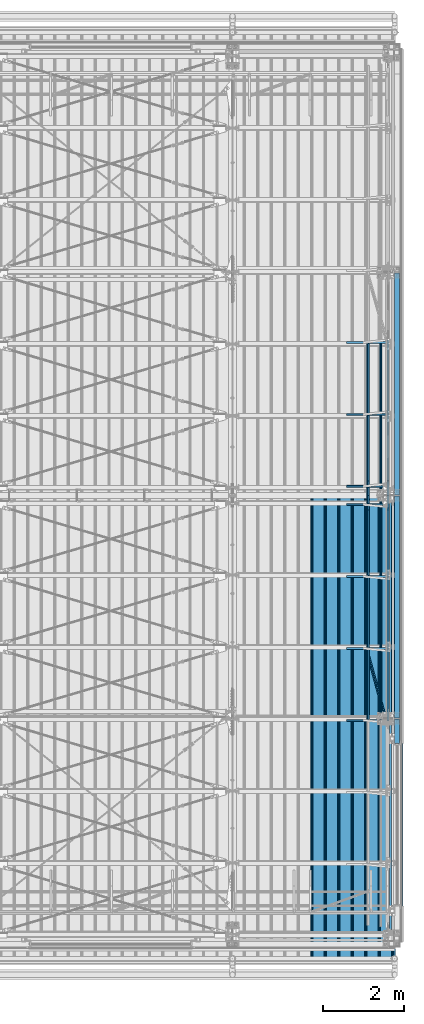
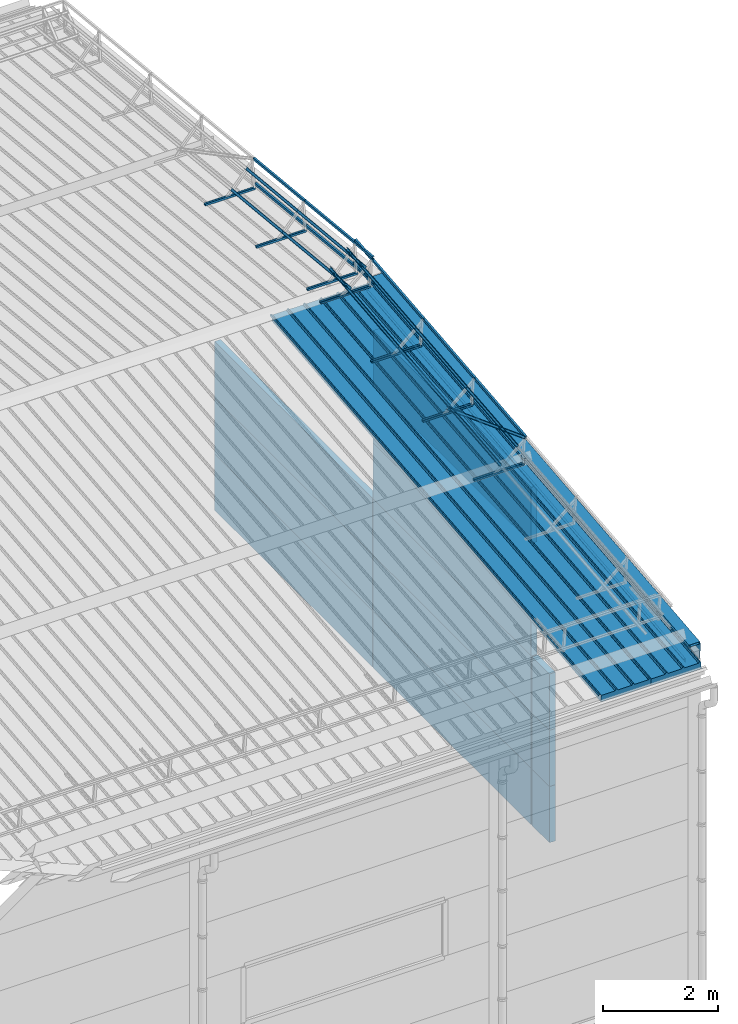
# One storey, part 73 of 709: 45 beams, 45 elements without a shape of their own.
"""IFC4 building model written with IfcOpenShell, lengths in millimetres."""

from ifc_helpers import new_model, si_unit, direction, frame, origin_with_axes, place, context, subcontext, project, spatial, line, indexed_curve, outline, extrude, material, element, aggregate, save


model = new_model("IFC4")

# Units and contexts
model_context = context("Model", 3, precision=0.2, world=origin_with_axes(), true_north=direction((0.0, 1.0)))
body_context = subcontext(model_context, "Body", "Model", "MODEL_VIEW")
ifc_project = project(units=[si_unit("LENGTHUNIT", "METRE", prefix="MILLI"), si_unit("AREAUNIT", "SQUARE_METRE"), si_unit("VOLUMEUNIT", "CUBIC_METRE"), si_unit("MASSUNIT", "GRAM", prefix="KILO"), si_unit("TIMEUNIT", "SECOND"), si_unit("PLANEANGLEUNIT", "RADIAN"), si_unit("SOLIDANGLEUNIT", "STERADIAN"), si_unit("THERMODYNAMICTEMPERATUREUNIT", "DEGREE_CELSIUS"), si_unit("LUMINOUSINTENSITYUNIT", "LUMEN")], contexts=[model_context])

# Site, building, storey
site_placement = place(None, origin_with_axes())
site = spatial("IfcSite", under=ifc_project, at=site_placement, CompositionType="ELEMENT")
building_placement = place(site_placement, origin_with_axes())
building = spatial("IfcBuilding", under=site, at=building_placement, Name="Undefined", CompositionType="ELEMENT")
storey_placement = place(building_placement, origin_with_axes())
storey = spatial("IfcBuildingStorey", under=building, at=storey_placement, Name="Undefined", CompositionType="ELEMENT", Elevation=0.0)

# Assembly, beam
assembly_1_placement = place(storey_placement, frame((49452.44, -410.89541, 7279.78979), z_axis=(1.0, 0.0, 0.0), x_axis=(0.0, 0.9950371902, 0.099503719)))
assembly_1 = element("IfcElementAssembly", 1, at=assembly_1_placement, inside=storey)
ifc_material_1 = material(Name="Insulation", Category="Insulation")
beam_1_placement = place(assembly_1_placement, origin_with_axes())
beam_1 = element("IfcBeam", 2, at=beam_1_placement, material=ifc_material_1, ObjectType="P-99", context=body_context, shape_type="SolidModel", body=[
    extrude(outline(indexed_curve([(-509.8453, 89.5), (-490.1547, 89.5), (-471.67949, 57.5), (-471.67949, -88.5), (-436.67949, -88.5), (-436.67949, -91.5), (562.55841, -91.5), (562.55841, -89.5), (527.55841, -89.5), (527.55841, 57.5), (510.2379, 88.5), (489.7621, 88.5), (472.44159, 58.5), (196.71923, 58.5), (177.66667, 91.5), (155.66667, 91.5), (136.61411, 58.5), (-136.61411, 58.5), (-155.66667, 91.5), (-177.66667, 91.5), (-196.71923, 58.5), (-469.94744, 58.5), (-489.0, 91.5), (-511.0, 91.5), (-527.16581, 63.5), (-525.43376, 62.5)], segments=[line(1, 2, 3, 4, 5, 6, 7, 8, 9, 10, 11, 12, 13, 14, 15, 16, 17, 18, 19, 20, 21, 22, 23, 24, 25, 26, 1)])), frame((0.0, 0.0, 0.0), z_axis=(-1.0, 0.0, 0.0), x_axis=(0.0, 0.0, 1.0)), (0.0, 0.0, -1.0), 11459.0),
])
aggregate(assembly_1, [beam_1])

assembly_2_placement = place(storey_placement, frame((48452.44, -410.89541, 7279.78979), z_axis=(1.0, 0.0, 0.0), x_axis=(0.0, 0.9950371902, 0.099503719)))
assembly_2 = element("IfcElementAssembly", 3, at=assembly_2_placement, inside=storey)
beam_2_placement = place(assembly_2_placement, origin_with_axes())
beam_2 = element("IfcBeam", 4, at=beam_2_placement, material=ifc_material_1, ObjectType="P-99", context=body_context, shape_type="SolidModel", body=[
    extrude(outline(indexed_curve([(-509.8453, 89.5), (-490.1547, 89.5), (-471.67949, 57.5), (-471.67949, -88.5), (-436.67949, -88.5), (-436.67949, -91.5), (562.55841, -91.5), (562.55841, -89.5), (527.55841, -89.5), (527.55841, 57.5), (510.2379, 88.5), (489.7621, 88.5), (472.44159, 58.5), (196.71923, 58.5), (177.66667, 91.5), (155.66667, 91.5), (136.61411, 58.5), (-136.61411, 58.5), (-155.66667, 91.5), (-177.66667, 91.5), (-196.71923, 58.5), (-469.94744, 58.5), (-489.0, 91.5), (-511.0, 91.5), (-527.16581, 63.5), (-525.43376, 62.5)], segments=[line(1, 2, 3, 4, 5, 6, 7, 8, 9, 10, 11, 12, 13, 14, 15, 16, 17, 18, 19, 20, 21, 22, 23, 24, 25, 26, 1)])), frame((0.0, 0.0, 0.0), z_axis=(-1.0, 0.0, 0.0), x_axis=(0.0, 0.0, 1.0)), (0.0, 0.0, -1.0), 11459.0),
])
aggregate(assembly_2, [beam_2])

assembly_3_placement = place(storey_placement, frame((49815.0, 5453.23325, 8045.59294), z_axis=(0.0, -0.099503719, 0.9950371902), x_axis=(-1.0, 0.0, 0.0)))
assembly_3 = element("IfcElementAssembly", 5, at=assembly_3_placement, inside=storey)
ifc_material_2 = material(Name="Steel_Undefined", Category="STEEL")
beam_3_placement = place(assembly_3_placement, origin_with_axes())
beam_3 = element("IfcBeam", 6, at=beam_3_placement, material=ifc_material_2, ObjectType="601", context=body_context, shape_type="SolidModel", body=[
    extrude(outline(indexed_curve([(-20.0, -25.0), (20.0, -25.0), (20.0, -22.5), (-17.5, -22.5), (-17.5, 22.5), (20.0, 22.5), (20.0, 25.0), (-20.0, 25.0)], segments=[line(1, 2, 3, 4, 5, 6, 7, 8, 1)])), frame((0.0, 0.0, 0.0), z_axis=(-1.0, 0.0, 0.0), x_axis=(0.0, 0.0, 1.0)), (0.0, 0.0, -1.0), 1000.0),
])
aggregate(assembly_3, [beam_3])

assembly_4_placement = place(storey_placement, frame((49815.0, 7226.5335, 8222.92296), z_axis=(0.0, -0.099503719, 0.9950371902), x_axis=(-1.0, 0.0, 0.0)))
assembly_4 = element("IfcElementAssembly", 7, at=assembly_4_placement, inside=storey)
beam_4_placement = place(assembly_4_placement, origin_with_axes())
beam_4 = element("IfcBeam", 8, at=beam_4_placement, material=ifc_material_2, ObjectType="601", context=body_context, shape_type="SolidModel", body=[
    extrude(outline(indexed_curve([(-20.0, -25.0), (20.0, -25.0), (20.0, -22.5), (-17.5, -22.5), (-17.5, 22.5), (20.0, 22.5), (20.0, 25.0), (-20.0, 25.0)], segments=[line(1, 2, 3, 4, 5, 6, 7, 8, 1)])), frame((0.0, 0.0, 0.0), z_axis=(-1.0, 0.0, 0.0), x_axis=(0.0, 0.0, 1.0)), (0.0, 0.0, -1.0), 1000.0),
])
aggregate(assembly_4, [beam_4])

assembly_5_placement = place(storey_placement, frame((49815.0, 8999.83375, 8400.25299), z_axis=(0.0, -0.099503719, 0.9950371902), x_axis=(-1.0, 0.0, 0.0)))
assembly_5 = element("IfcElementAssembly", 9, at=assembly_5_placement, inside=storey)
beam_5_placement = place(assembly_5_placement, origin_with_axes())
beam_5 = element("IfcBeam", 10, at=beam_5_placement, material=ifc_material_2, ObjectType="601", context=body_context, shape_type="SolidModel", body=[
    extrude(outline(indexed_curve([(-20.0, -25.0), (20.0, -25.0), (20.0, -22.5), (-17.5, -22.5), (-17.5, 22.5), (20.0, 22.5), (20.0, 25.0), (-20.0, 25.0)], segments=[line(1, 2, 3, 4, 5, 6, 7, 8, 1)])), frame((0.0, 0.0, 0.0), z_axis=(-1.0, 0.0, 0.0), x_axis=(0.0, 0.0, 1.0)), (0.0, 0.0, -1.0), 1000.0),
])
aggregate(assembly_5, [beam_5])

assembly_6_placement = place(storey_placement, frame((49815.0, 10773.134, 8577.58301), z_axis=(0.0, -0.099503719, 0.9950371902), x_axis=(-1.0, 0.0, 0.0)))
assembly_6 = element("IfcElementAssembly", 11, at=assembly_6_placement, inside=storey)
beam_6_placement = place(assembly_6_placement, origin_with_axes())
beam_6 = element("IfcBeam", 12, at=beam_6_placement, material=ifc_material_2, ObjectType="601", context=body_context, shape_type="SolidModel", body=[
    extrude(outline(indexed_curve([(-20.0, -25.0), (20.0, -25.0), (20.0, -22.5), (-17.5, -22.5), (-17.5, 22.5), (20.0, 22.5), (20.0, 25.0), (-20.0, 25.0)], segments=[line(1, 2, 3, 4, 5, 6, 7, 8, 1)])), frame((0.0, 0.0, 0.0), z_axis=(-1.0, 0.0, 0.0), x_axis=(0.0, 0.0, 1.0)), (0.0, 0.0, -1.0), 1000.0),
])
aggregate(assembly_6, [beam_6])

assembly_7_placement = place(storey_placement, frame((49835.0, 5395.5211, 8622.71451), z_axis=(1.0, 0.0, 0.0), x_axis=(0.0, 0.9950371902, 0.099503719)))
assembly_7 = element("IfcElementAssembly", 13, at=assembly_7_placement, inside=storey)
beam_7_placement = place(assembly_7_placement, origin_with_axes())
beam_7 = element("IfcBeam", 14, at=beam_7_placement, material=ifc_material_2, ObjectType="610", context=body_context, shape_type="SolidModel", body=[
    extrude(outline(indexed_curve([(-20.0, -25.0), (20.0, -25.0), (20.0, -22.5), (-17.5, -22.5), (-17.5, 22.5), (20.0, 22.5), (20.0, 25.0), (-20.0, 25.0)], segments=[line(1, 2, 3, 4, 5, 6, 7, 8, 1)])), frame((0.0, 0.0, 0.0), z_axis=(-1.0, 0.0, 0.0), x_axis=(0.0, 0.0, 1.0)), (0.0, 0.0, -1.0), 1782.14469),
])
aggregate(assembly_7, [beam_7])

assembly_8_placement = place(storey_placement, frame((49835.0, 5445.27295, 8125.19591), z_axis=(1.0, 0.0, 0.0), x_axis=(0.0, 0.9950371902, 0.099503719)))
assembly_8 = element("IfcElementAssembly", 15, at=assembly_8_placement, inside=storey)
beam_8_placement = place(assembly_8_placement, origin_with_axes())
beam_8 = element("IfcBeam", 16, at=beam_8_placement, material=ifc_material_2, ObjectType="610", context=body_context, shape_type="SolidModel", body=[
    extrude(outline(indexed_curve([(-20.0, -25.0), (20.0, -25.0), (20.0, -22.5), (-17.5, -22.5), (-17.5, 22.5), (20.0, 22.5), (20.0, 25.0), (-20.0, 25.0)], segments=[line(1, 2, 3, 4, 5, 6, 7, 8, 1)])), frame((0.0, 0.0, 0.0), z_axis=(-1.0, 0.0, 0.0), x_axis=(0.0, 0.0, 1.0)), (0.0, 0.0, -1.0), 1782.14469),
])
aggregate(assembly_8, [beam_8])

assembly_9_placement = place(storey_placement, frame((49659.43651, 5408.18585, 8496.06695), z_axis=(-0.707106781, -0.070359754, 0.703597545), x_axis=(0.0, 0.9950371902, 0.099503719)))
assembly_9 = element("IfcElementAssembly", 17, at=assembly_9_placement, inside=storey)
beam_9_placement = place(assembly_9_placement, origin_with_axes())
beam_9 = element("IfcBeam", 18, at=beam_9_placement, material=ifc_material_2, ObjectType="610", context=body_context, shape_type="SolidModel", body=[
    extrude(outline(indexed_curve([(-20.0, -25.0), (20.0, -25.0), (20.0, -22.5), (-17.5, -22.5), (-17.5, 22.5), (20.0, 22.5), (20.0, 25.0), (-20.0, 25.0)], segments=[line(1, 2, 3, 4, 5, 6, 7, 8, 1)])), frame((0.0, 0.0, 0.0), z_axis=(-1.0, 0.0, 0.0), x_axis=(0.0, 0.0, 1.0)), (0.0, 0.0, -1.0), 1782.14469),
])
aggregate(assembly_9, [beam_9])

assembly_10_placement = place(storey_placement, frame((49342.27922, 5439.74418, 8180.48365), z_axis=(-0.707106781, -0.070359754, 0.703597545), x_axis=(0.0, 0.9950371902, 0.099503719)))
assembly_10 = element("IfcElementAssembly", 19, at=assembly_10_placement, inside=storey)
beam_10_placement = place(assembly_10_placement, origin_with_axes())
beam_10 = element("IfcBeam", 20, at=beam_10_placement, material=ifc_material_2, ObjectType="610", context=body_context, shape_type="SolidModel", body=[
    extrude(outline(indexed_curve([(-20.0, -25.0), (20.0, -25.0), (20.0, -22.5), (-17.5, -22.5), (-17.5, 22.5), (20.0, 22.5), (20.0, 25.0), (-20.0, 25.0)], segments=[line(1, 2, 3, 4, 5, 6, 7, 8, 1)])), frame((0.0, 0.0, 0.0), z_axis=(-1.0, 0.0, 0.0), x_axis=(0.0, 0.0, 1.0)), (0.0, 0.0, -1.0), 1782.14469),
])
aggregate(assembly_10, [beam_10])

assembly_11_placement = place(storey_placement, frame((49835.0, 7168.82134, 8800.04453), z_axis=(1.0, 0.0, 0.0), x_axis=(0.0, 0.9950371902, 0.099503719)))
assembly_11 = element("IfcElementAssembly", 21, at=assembly_11_placement, inside=storey)
beam_11_placement = place(assembly_11_placement, origin_with_axes())
beam_11 = element("IfcBeam", 22, at=beam_11_placement, material=ifc_material_2, ObjectType="610", context=body_context, shape_type="SolidModel", body=[
    extrude(outline(indexed_curve([(-20.0, -25.0), (20.0, -25.0), (20.0, -22.5), (-17.5, -22.5), (-17.5, 22.5), (20.0, 22.5), (20.0, 25.0), (-20.0, 25.0)], segments=[line(1, 2, 3, 4, 5, 6, 7, 8, 1)])), frame((0.0, 0.0, 0.0), z_axis=(-1.0, 0.0, 0.0), x_axis=(0.0, 0.0, 1.0)), (0.0, 0.0, -1.0), 1782.14469),
])
aggregate(assembly_11, [beam_11])

assembly_12_placement = place(storey_placement, frame((49835.0, 7218.5732, 8302.52594), z_axis=(1.0, 0.0, 0.0), x_axis=(0.0, 0.9950371902, 0.099503719)))
assembly_12 = element("IfcElementAssembly", 23, at=assembly_12_placement, inside=storey)
beam_12_placement = place(assembly_12_placement, origin_with_axes())
beam_12 = element("IfcBeam", 24, at=beam_12_placement, material=ifc_material_2, ObjectType="610", context=body_context, shape_type="SolidModel", body=[
    extrude(outline(indexed_curve([(-20.0, -25.0), (20.0, -25.0), (20.0, -22.5), (-17.5, -22.5), (-17.5, 22.5), (20.0, 22.5), (20.0, 25.0), (-20.0, 25.0)], segments=[line(1, 2, 3, 4, 5, 6, 7, 8, 1)])), frame((0.0, 0.0, 0.0), z_axis=(-1.0, 0.0, 0.0), x_axis=(0.0, 0.0, 1.0)), (0.0, 0.0, -1.0), 1782.14469),
])
aggregate(assembly_12, [beam_12])

assembly_13_placement = place(storey_placement, frame((49659.43651, 7181.4861, 8673.39698), z_axis=(-0.707106781, -0.070359754, 0.703597545), x_axis=(0.0, 0.9950371902, 0.099503719)))
assembly_13 = element("IfcElementAssembly", 25, at=assembly_13_placement, inside=storey)
beam_13_placement = place(assembly_13_placement, origin_with_axes())
beam_13 = element("IfcBeam", 26, at=beam_13_placement, material=ifc_material_2, ObjectType="610", context=body_context, shape_type="SolidModel", body=[
    extrude(outline(indexed_curve([(-20.0, -25.0), (20.0, -25.0), (20.0, -22.5), (-17.5, -22.5), (-17.5, 22.5), (20.0, 22.5), (20.0, 25.0), (-20.0, 25.0)], segments=[line(1, 2, 3, 4, 5, 6, 7, 8, 1)])), frame((0.0, 0.0, 0.0), z_axis=(-1.0, 0.0, 0.0), x_axis=(0.0, 0.0, 1.0)), (0.0, 0.0, -1.0), 1782.14469),
])
aggregate(assembly_13, [beam_13])

assembly_14_placement = place(storey_placement, frame((49342.27922, 7213.04443, 8357.81368), z_axis=(-0.707106781, -0.070359754, 0.703597545), x_axis=(0.0, 0.9950371902, 0.099503719)))
assembly_14 = element("IfcElementAssembly", 27, at=assembly_14_placement, inside=storey)
beam_14_placement = place(assembly_14_placement, origin_with_axes())
beam_14 = element("IfcBeam", 28, at=beam_14_placement, material=ifc_material_2, ObjectType="610", context=body_context, shape_type="SolidModel", body=[
    extrude(outline(indexed_curve([(-20.0, -25.0), (20.0, -25.0), (20.0, -22.5), (-17.5, -22.5), (-17.5, 22.5), (20.0, 22.5), (20.0, 25.0), (-20.0, 25.0)], segments=[line(1, 2, 3, 4, 5, 6, 7, 8, 1)])), frame((0.0, 0.0, 0.0), z_axis=(-1.0, 0.0, 0.0), x_axis=(0.0, 0.0, 1.0)), (0.0, 0.0, -1.0), 1782.14469),
])
aggregate(assembly_14, [beam_14])

assembly_15_placement = place(storey_placement, frame((49835.0, 8942.12159, 8977.37456), z_axis=(1.0, 0.0, 0.0), x_axis=(0.0, 0.9950371902, 0.099503719)))
assembly_15 = element("IfcElementAssembly", 29, at=assembly_15_placement, inside=storey)
beam_15_placement = place(assembly_15_placement, origin_with_axes())
beam_15 = element("IfcBeam", 30, at=beam_15_placement, material=ifc_material_2, ObjectType="611", context=body_context, shape_type="SolidModel", body=[
    extrude(outline(indexed_curve([(-20.0, -25.0), (20.0, -25.0), (20.0, -22.5), (-17.5, -22.5), (-17.5, 22.5), (20.0, 22.5), (20.0, 25.0), (-20.0, 25.0)], segments=[line(1, 2, 3, 4, 5, 6, 7, 8, 1)])), frame((0.0, 0.0, 0.0), z_axis=(-1.0, 0.0, 0.0), x_axis=(0.0, 0.0, 1.0)), (0.0, 0.0, -1.0), 2382.14469),
])
aggregate(assembly_15, [beam_15])

assembly_16_placement = place(storey_placement, frame((49835.0, 8991.87345, 8479.85596), z_axis=(1.0, 0.0, 0.0), x_axis=(0.0, 0.9950371902, 0.099503719)))
assembly_16 = element("IfcElementAssembly", 31, at=assembly_16_placement, inside=storey)
beam_16_placement = place(assembly_16_placement, origin_with_axes())
beam_16 = element("IfcBeam", 32, at=beam_16_placement, material=ifc_material_2, ObjectType="611", context=body_context, shape_type="SolidModel", body=[
    extrude(outline(indexed_curve([(-20.0, -25.0), (20.0, -25.0), (20.0, -22.5), (-17.5, -22.5), (-17.5, 22.5), (20.0, 22.5), (20.0, 25.0), (-20.0, 25.0)], segments=[line(1, 2, 3, 4, 5, 6, 7, 8, 1)])), frame((0.0, 0.0, 0.0), z_axis=(-1.0, 0.0, 0.0), x_axis=(0.0, 0.0, 1.0)), (0.0, 0.0, -1.0), 2382.14469),
])
aggregate(assembly_16, [beam_16])

assembly_17_placement = place(storey_placement, frame((49659.43651, 8954.78635, 8850.727), z_axis=(-0.707106781, -0.070359754, 0.703597545), x_axis=(0.0, 0.9950371902, 0.099503719)))
assembly_17 = element("IfcElementAssembly", 33, at=assembly_17_placement, inside=storey)
beam_17_placement = place(assembly_17_placement, origin_with_axes())
beam_17 = element("IfcBeam", 34, at=beam_17_placement, material=ifc_material_2, ObjectType="611", context=body_context, shape_type="SolidModel", body=[
    extrude(outline(indexed_curve([(-20.0, -25.0), (20.0, -25.0), (20.0, -22.5), (-17.5, -22.5), (-17.5, 22.5), (20.0, 22.5), (20.0, 25.0), (-20.0, 25.0)], segments=[line(1, 2, 3, 4, 5, 6, 7, 8, 1)])), frame((0.0, 0.0, 0.0), z_axis=(-1.0, 0.0, 0.0), x_axis=(0.0, 0.0, 1.0)), (0.0, 0.0, -1.0), 2382.14469),
])
aggregate(assembly_17, [beam_17])

assembly_18_placement = place(storey_placement, frame((49342.27922, 8986.34468, 8535.1437), z_axis=(-0.707106781, -0.070359754, 0.703597545), x_axis=(0.0, 0.9950371902, 0.099503719)))
assembly_18 = element("IfcElementAssembly", 35, at=assembly_18_placement, inside=storey)
beam_18_placement = place(assembly_18_placement, origin_with_axes())
beam_18 = element("IfcBeam", 36, at=beam_18_placement, material=ifc_material_2, ObjectType="611", context=body_context, shape_type="SolidModel", body=[
    extrude(outline(indexed_curve([(-20.0, -25.0), (20.0, -25.0), (20.0, -22.5), (-17.5, -22.5), (-17.5, 22.5), (20.0, 22.5), (20.0, 25.0), (-20.0, 25.0)], segments=[line(1, 2, 3, 4, 5, 6, 7, 8, 1)])), frame((0.0, 0.0, 0.0), z_axis=(-1.0, 0.0, 0.0), x_axis=(0.0, 0.0, 1.0)), (0.0, 0.0, -1.0), 2382.14469),
])
aggregate(assembly_18, [beam_18])

assembly_19_placement = place(storey_placement, frame((49800.85786, 5394.1139, 8636.78646), z_axis=(-0.707106781, -0.070359754, 0.703597545), x_axis=(-0.2585142339, 0.9518781635, -0.1646157729)))
assembly_19 = element("IfcElementAssembly", 37, at=assembly_19_placement, inside=storey)
beam_19_placement = place(assembly_19_placement, origin_with_axes())
beam_19 = element("IfcBeam", 38, at=beam_19_placement, material=ifc_material_2, ObjectType="612", context=body_context, shape_type="SolidModel", body=[
    extrude(outline(indexed_curve([(-20.0, -25.0), (20.0, -25.0), (20.0, -22.5), (-17.5, -22.5), (-17.5, 22.5), (20.0, 22.5), (20.0, 25.0), (-20.0, 25.0)], segments=[line(1, 2, 3, 4, 5, 6, 7, 8, 1)])), frame((0.0, 0.0, 0.0), z_axis=(-1.0, 0.0, 0.0), x_axis=(0.0, 0.0, 1.0)), (0.0, 0.0, -1.0), 1914.6905),
])
aggregate(assembly_19, [beam_19])

assembly_20_placement = place(storey_placement, frame((49815.0, 11226.866, 8577.58301), z_axis=(0.0, 0.099503719, 0.9950371902), x_axis=(-1.0, 0.0, 0.0)))
assembly_20 = element("IfcElementAssembly", 39, at=assembly_20_placement, inside=storey)
beam_20_placement = place(assembly_20_placement, origin_with_axes())
beam_20 = element("IfcBeam", 40, at=beam_20_placement, material=ifc_material_2, ObjectType="601", context=body_context, shape_type="SolidModel", body=[
    extrude(outline(indexed_curve([(-20.0, -25.0), (20.0, -25.0), (20.0, -22.5), (-17.5, -22.5), (-17.5, 22.5), (20.0, 22.5), (20.0, 25.0), (-20.0, 25.0)], segments=[line(1, 2, 3, 4, 5, 6, 7, 8, 1)])), frame((0.0, 0.0, 0.0), z_axis=(-1.0, 0.0, 0.0), x_axis=(0.0, 0.0, 1.0)), (0.0, 0.0, -1.0), 1000.0),
])
aggregate(assembly_20, [beam_20])

assembly_21_placement = place(storey_placement, frame((49815.0, 13000.16625, 8400.25299), z_axis=(0.0, 0.099503719, 0.9950371902), x_axis=(-1.0, 0.0, 0.0)))
assembly_21 = element("IfcElementAssembly", 41, at=assembly_21_placement, inside=storey)
beam_21_placement = place(assembly_21_placement, origin_with_axes())
beam_21 = element("IfcBeam", 42, at=beam_21_placement, material=ifc_material_2, ObjectType="601", context=body_context, shape_type="SolidModel", body=[
    extrude(outline(indexed_curve([(-20.0, -25.0), (20.0, -25.0), (20.0, -22.5), (-17.5, -22.5), (-17.5, 22.5), (20.0, 22.5), (20.0, 25.0), (-20.0, 25.0)], segments=[line(1, 2, 3, 4, 5, 6, 7, 8, 1)])), frame((0.0, 0.0, 0.0), z_axis=(-1.0, 0.0, 0.0), x_axis=(0.0, 0.0, 1.0)), (0.0, 0.0, -1.0), 1000.0),
])
aggregate(assembly_21, [beam_21])

assembly_22_placement = place(storey_placement, frame((49815.0, 14773.4665, 8222.92296), z_axis=(0.0, 0.099503719, 0.9950371902), x_axis=(-1.0, 0.0, 0.0)))
assembly_22 = element("IfcElementAssembly", 43, at=assembly_22_placement, inside=storey)
beam_22_placement = place(assembly_22_placement, origin_with_axes())
beam_22 = element("IfcBeam", 44, at=beam_22_placement, material=ifc_material_2, ObjectType="601", context=body_context, shape_type="SolidModel", body=[
    extrude(outline(indexed_curve([(-20.0, -25.0), (20.0, -25.0), (20.0, -22.5), (-17.5, -22.5), (-17.5, 22.5), (20.0, 22.5), (20.0, 25.0), (-20.0, 25.0)], segments=[line(1, 2, 3, 4, 5, 6, 7, 8, 1)])), frame((0.0, 0.0, 0.0), z_axis=(-1.0, 0.0, 0.0), x_axis=(0.0, 0.0, 1.0)), (0.0, 0.0, -1.0), 1000.0),
])
aggregate(assembly_22, [beam_22])

assembly_23_placement = place(storey_placement, frame((49835.0, 10687.55585, 9214.40681), z_axis=(1.0, 0.0, 0.0), x_axis=(0.0, 0.9950371902, -0.099503719)))
assembly_23 = element("IfcElementAssembly", 45, at=assembly_23_placement, inside=storey)
beam_23_placement = place(assembly_23_placement, origin_with_axes())
beam_23 = element("IfcBeam", 46, at=beam_23_placement, material=ifc_material_2, ObjectType="611", context=body_context, shape_type="SolidModel", body=[
    extrude(outline(indexed_curve([(-20.0, -25.0), (20.0, -25.0), (20.0, -22.5), (-17.5, -22.5), (-17.5, 22.5), (20.0, 22.5), (20.0, 25.0), (-20.0, 25.0)], segments=[line(1, 2, 3, 4, 5, 6, 7, 8, 1)])), frame((0.0, 0.0, 0.0), z_axis=(-1.0, 0.0, 0.0), x_axis=(0.0, 0.0, 1.0)), (0.0, 0.0, -1.0), 2382.14469),
])
aggregate(assembly_23, [beam_23])

assembly_24_placement = place(storey_placement, frame((49835.0, 10637.80399, 8716.88822), z_axis=(1.0, 0.0, 0.0), x_axis=(0.0, 0.9950371902, -0.099503719)))
assembly_24 = element("IfcElementAssembly", 47, at=assembly_24_placement, inside=storey)
beam_24_placement = place(assembly_24_placement, origin_with_axes())
beam_24 = element("IfcBeam", 48, at=beam_24_placement, material=ifc_material_2, ObjectType="611", context=body_context, shape_type="SolidModel", body=[
    extrude(outline(indexed_curve([(-20.0, -25.0), (20.0, -25.0), (20.0, -22.5), (-17.5, -22.5), (-17.5, 22.5), (20.0, 22.5), (20.0, 25.0), (-20.0, 25.0)], segments=[line(1, 2, 3, 4, 5, 6, 7, 8, 1)])), frame((0.0, 0.0, 0.0), z_axis=(-1.0, 0.0, 0.0), x_axis=(0.0, 0.0, 1.0)), (0.0, 0.0, -1.0), 2382.14469),
])
aggregate(assembly_24, [beam_24])

assembly_25_placement = place(storey_placement, frame((49659.43651, 10674.89109, 9087.75926), z_axis=(-0.7071067814, 0.0703597545, 0.7035975445), x_axis=(0.0, 0.9950371902, -0.099503719)))
assembly_25 = element("IfcElementAssembly", 49, at=assembly_25_placement, inside=storey)
beam_25_placement = place(assembly_25_placement, origin_with_axes())
beam_25 = element("IfcBeam", 50, at=beam_25_placement, material=ifc_material_2, ObjectType="611", context=body_context, shape_type="SolidModel", body=[
    extrude(outline(indexed_curve([(-20.0, -25.0), (20.0, -25.0), (20.0, -22.5), (-17.5, -22.5), (-17.5, 22.5), (20.0, 22.5), (20.0, 25.0), (-20.0, 25.0)], segments=[line(1, 2, 3, 4, 5, 6, 7, 8, 1)])), frame((0.0, 0.0, 0.0), z_axis=(-1.0, 0.0, 0.0), x_axis=(0.0, 0.0, 1.0)), (0.0, 0.0, -1.0), 2382.14469),
])
aggregate(assembly_25, [beam_25])

assembly_26_placement = place(storey_placement, frame((49342.27922, 10643.33276, 8772.17596), z_axis=(-0.7071067814, 0.0703597545, 0.7035975445), x_axis=(0.0, 0.9950371902, -0.099503719)))
assembly_26 = element("IfcElementAssembly", 51, at=assembly_26_placement, inside=storey)
beam_26_placement = place(assembly_26_placement, origin_with_axes())
beam_26 = element("IfcBeam", 52, at=beam_26_placement, material=ifc_material_2, ObjectType="611", context=body_context, shape_type="SolidModel", body=[
    extrude(outline(indexed_curve([(-20.0, -25.0), (20.0, -25.0), (20.0, -22.5), (-17.5, -22.5), (-17.5, 22.5), (20.0, 22.5), (20.0, 25.0), (-20.0, 25.0)], segments=[line(1, 2, 3, 4, 5, 6, 7, 8, 1)])), frame((0.0, 0.0, 0.0), z_axis=(-1.0, 0.0, 0.0), x_axis=(0.0, 0.0, 1.0)), (0.0, 0.0, -1.0), 2382.14469),
])
aggregate(assembly_26, [beam_26])

assembly_27_placement = place(storey_placement, frame((49835.0, 13057.87841, 8977.37456), z_axis=(1.0, 0.0, 0.0), x_axis=(0.0, 0.9950371902, -0.099503719)))
assembly_27 = element("IfcElementAssembly", 53, at=assembly_27_placement, inside=storey)
beam_27_placement = place(assembly_27_placement, origin_with_axes())
beam_27 = element("IfcBeam", 54, at=beam_27_placement, material=ifc_material_2, ObjectType="610", context=body_context, shape_type="SolidModel", body=[
    extrude(outline(indexed_curve([(-20.0, -25.0), (20.0, -25.0), (20.0, -22.5), (-17.5, -22.5), (-17.5, 22.5), (20.0, 22.5), (20.0, 25.0), (-20.0, 25.0)], segments=[line(1, 2, 3, 4, 5, 6, 7, 8, 1)])), frame((0.0, 0.0, 0.0), z_axis=(-1.0, 0.0, 0.0), x_axis=(0.0, 0.0, 1.0)), (0.0, 0.0, -1.0), 1782.14469),
])
aggregate(assembly_27, [beam_27])

assembly_28_placement = place(storey_placement, frame((49835.0, 13008.12655, 8479.85596), z_axis=(1.0, 0.0, 0.0), x_axis=(0.0, 0.9950371902, -0.099503719)))
assembly_28 = element("IfcElementAssembly", 55, at=assembly_28_placement, inside=storey)
beam_28_placement = place(assembly_28_placement, origin_with_axes())
beam_28 = element("IfcBeam", 56, at=beam_28_placement, material=ifc_material_2, ObjectType="610", context=body_context, shape_type="SolidModel", body=[
    extrude(outline(indexed_curve([(-20.0, -25.0), (20.0, -25.0), (20.0, -22.5), (-17.5, -22.5), (-17.5, 22.5), (20.0, 22.5), (20.0, 25.0), (-20.0, 25.0)], segments=[line(1, 2, 3, 4, 5, 6, 7, 8, 1)])), frame((0.0, 0.0, 0.0), z_axis=(-1.0, 0.0, 0.0), x_axis=(0.0, 0.0, 1.0)), (0.0, 0.0, -1.0), 1782.14469),
])
aggregate(assembly_28, [beam_28])

assembly_29_placement = place(storey_placement, frame((49659.43651, 13045.21365, 8850.727), z_axis=(-0.7071067814, 0.0703597545, 0.7035975445), x_axis=(0.0, 0.9950371902, -0.099503719)))
assembly_29 = element("IfcElementAssembly", 57, at=assembly_29_placement, inside=storey)
beam_29_placement = place(assembly_29_placement, origin_with_axes())
beam_29 = element("IfcBeam", 58, at=beam_29_placement, material=ifc_material_2, ObjectType="610", context=body_context, shape_type="SolidModel", body=[
    extrude(outline(indexed_curve([(-20.0, -25.0), (20.0, -25.0), (20.0, -22.5), (-17.5, -22.5), (-17.5, 22.5), (20.0, 22.5), (20.0, 25.0), (-20.0, 25.0)], segments=[line(1, 2, 3, 4, 5, 6, 7, 8, 1)])), frame((0.0, 0.0, 0.0), z_axis=(-1.0, 0.0, 0.0), x_axis=(0.0, 0.0, 1.0)), (0.0, 0.0, -1.0), 1782.14469),
])
aggregate(assembly_29, [beam_29])

assembly_30_placement = place(storey_placement, frame((49342.27922, 13013.65532, 8535.1437), z_axis=(-0.7071067814, 0.0703597545, 0.7035975445), x_axis=(0.0, 0.9950371902, -0.099503719)))
assembly_30 = element("IfcElementAssembly", 59, at=assembly_30_placement, inside=storey)
beam_30_placement = place(assembly_30_placement, origin_with_axes())
beam_30 = element("IfcBeam", 60, at=beam_30_placement, material=ifc_material_2, ObjectType="610", context=body_context, shape_type="SolidModel", body=[
    extrude(outline(indexed_curve([(-20.0, -25.0), (20.0, -25.0), (20.0, -22.5), (-17.5, -22.5), (-17.5, 22.5), (20.0, 22.5), (20.0, 25.0), (-20.0, 25.0)], segments=[line(1, 2, 3, 4, 5, 6, 7, 8, 1)])), frame((0.0, 0.0, 0.0), z_axis=(-1.0, 0.0, 0.0), x_axis=(0.0, 0.0, 1.0)), (0.0, 0.0, -1.0), 1782.14469),
])
aggregate(assembly_30, [beam_30])

assembly_31_placement = place(storey_placement, frame((50060.0, 4880.0, 895.0), z_axis=(0.0, 0.0, -1.0), x_axis=(0.0, 1.0, 0.0)))
assembly_31 = element("IfcElementAssembly", 61, at=assembly_31_placement, inside=storey)
beam_31_placement = place(assembly_31_placement, origin_with_axes())
beam_31 = element("IfcBeam", 62, at=beam_31_placement, material=ifc_material_1, ObjectType="P-144", context=body_context, shape_type="SolidModel", body=[
    extrude(outline(indexed_curve([(-595.0, -60.0), (595.0, -60.0), (595.0, 60.0), (-595.0, 60.0)], segments=[line(1, 2, 3, 4, 1)])), frame((0.0, 0.0, 0.0), z_axis=(-1.0, 0.0, 0.0), x_axis=(0.0, 0.0, 1.0)), (0.0, 0.0, -1.0), 610.0),
])
aggregate(assembly_31, [beam_31])

assembly_32_placement = place(storey_placement, frame((50060.0, 4880.0, 2085.0), z_axis=(0.0, 0.0, -1.0), x_axis=(0.0, 1.0, 0.0)))
assembly_32 = element("IfcElementAssembly", 63, at=assembly_32_placement, inside=storey)
beam_32_placement = place(assembly_32_placement, origin_with_axes())
beam_32 = element("IfcBeam", 64, at=beam_32_placement, material=ifc_material_1, ObjectType="P-144", context=body_context, shape_type="SolidModel", body=[
    extrude(outline(indexed_curve([(-595.0, -60.0), (595.0, -60.0), (595.0, 60.0), (-595.0, 60.0)], segments=[line(1, 2, 3, 4, 1)])), frame((0.0, 0.0, 0.0), z_axis=(-1.0, 0.0, 0.0), x_axis=(0.0, 0.0, 1.0)), (0.0, 0.0, -1.0), 610.0),
])
aggregate(assembly_32, [beam_32])

assembly_33_placement = place(storey_placement, frame((50060.0, 4880.0, 3275.0), z_axis=(0.0, 0.0, -1.0), x_axis=(0.0, 1.0, 0.0)))
assembly_33 = element("IfcElementAssembly", 65, at=assembly_33_placement, inside=storey)
beam_33_placement = place(assembly_33_placement, origin_with_axes())
beam_33 = element("IfcBeam", 66, at=beam_33_placement, material=ifc_material_1, ObjectType="P-144", context=body_context, shape_type="SolidModel", body=[
    extrude(outline(indexed_curve([(-595.0, -60.0), (595.0, -60.0), (595.0, 60.0), (-595.0, 60.0)], segments=[line(1, 2, 3, 4, 1)])), frame((0.0, 0.0, 0.0), z_axis=(-1.0, 0.0, 0.0), x_axis=(0.0, 0.0, 1.0)), (0.0, 0.0, -1.0), 610.0),
])
aggregate(assembly_33, [beam_33])

assembly_34_placement = place(storey_placement, frame((50060.0, 5510.0, 895.0), z_axis=(0.0, 0.0, -1.0), x_axis=(0.0, 1.0, 0.0)))
assembly_34 = element("IfcElementAssembly", 67, at=assembly_34_placement, inside=storey)
beam_34_placement = place(assembly_34_placement, origin_with_axes())
beam_34 = element("IfcBeam", 68, at=beam_34_placement, material=ifc_material_1, ObjectType="P-135", context=body_context, shape_type="SolidModel", body=[
    extrude(outline(indexed_curve([(-595.0, -60.0), (595.0, -60.0), (595.0, 60.0), (-595.0, 60.0)], segments=[line(1, 2, 3, 4, 1)])), frame((0.0, 0.0, 0.0), z_axis=(-1.0, 0.0, 0.0), x_axis=(0.0, 0.0, 1.0)), (0.0, 0.0, -1.0), 5480.0),
])
aggregate(assembly_34, [beam_34])

assembly_35_placement = place(storey_placement, frame((50060.0, 5510.0, 2085.0), z_axis=(0.0, 0.0, -1.0), x_axis=(0.0, 1.0, 0.0)))
assembly_35 = element("IfcElementAssembly", 69, at=assembly_35_placement, inside=storey)
beam_35_placement = place(assembly_35_placement, origin_with_axes())
beam_35 = element("IfcBeam", 70, at=beam_35_placement, material=ifc_material_1, ObjectType="P-135", context=body_context, shape_type="SolidModel", body=[
    extrude(outline(indexed_curve([(-595.0, -60.0), (595.0, -60.0), (595.0, 60.0), (-595.0, 60.0)], segments=[line(1, 2, 3, 4, 1)])), frame((0.0, 0.0, 0.0), z_axis=(-1.0, 0.0, 0.0), x_axis=(0.0, 0.0, 1.0)), (0.0, 0.0, -1.0), 5480.0),
])
aggregate(assembly_35, [beam_35])

assembly_36_placement = place(storey_placement, frame((50060.0, 5510.0, 3275.0), z_axis=(0.0, 0.0, -1.0), x_axis=(0.0, 1.0, 0.0)))
assembly_36 = element("IfcElementAssembly", 71, at=assembly_36_placement, inside=storey)
beam_36_placement = place(assembly_36_placement, origin_with_axes())
beam_36 = element("IfcBeam", 72, at=beam_36_placement, material=ifc_material_1, ObjectType="P-135", context=body_context, shape_type="SolidModel", body=[
    extrude(outline(indexed_curve([(-595.0, -60.0), (595.0, -60.0), (595.0, 60.0), (-595.0, 60.0)], segments=[line(1, 2, 3, 4, 1)])), frame((0.0, 0.0, 0.0), z_axis=(-1.0, 0.0, 0.0), x_axis=(0.0, 0.0, 1.0)), (0.0, 0.0, -1.0), 5480.0),
])
aggregate(assembly_36, [beam_36])

assembly_37_placement = place(storey_placement, frame((50060.0, 5510.0, 4465.0), z_axis=(0.0, 0.0, -1.0), x_axis=(0.0, 1.0, 0.0)))
assembly_37 = element("IfcElementAssembly", 73, at=assembly_37_placement, inside=storey)
beam_37_placement = place(assembly_37_placement, origin_with_axes())
beam_37 = element("IfcBeam", 74, at=beam_37_placement, material=ifc_material_1, ObjectType="P-135", context=body_context, shape_type="SolidModel", body=[
    extrude(outline(indexed_curve([(-595.0, -60.0), (595.0, -60.0), (595.0, 60.0), (-595.0, 60.0)], segments=[line(1, 2, 3, 4, 1)])), frame((0.0, 0.0, 0.0), z_axis=(-1.0, 0.0, 0.0), x_axis=(0.0, 0.0, 1.0)), (0.0, 0.0, -1.0), 5480.0),
])
aggregate(assembly_37, [beam_37])

assembly_38_placement = place(storey_placement, frame((50060.0, 5510.0, 5655.0), z_axis=(0.0, 0.0, -1.0), x_axis=(0.0, 1.0, 0.0)))
assembly_38 = element("IfcElementAssembly", 75, at=assembly_38_placement, inside=storey)
beam_38_placement = place(assembly_38_placement, origin_with_axes())
beam_38 = element("IfcBeam", 76, at=beam_38_placement, material=ifc_material_1, ObjectType="P-135", context=body_context, shape_type="SolidModel", body=[
    extrude(outline(indexed_curve([(-595.0, -60.0), (595.0, -60.0), (595.0, 60.0), (-595.0, 60.0)], segments=[line(1, 2, 3, 4, 1)])), frame((0.0, 0.0, 0.0), z_axis=(-1.0, 0.0, 0.0), x_axis=(0.0, 0.0, 1.0)), (0.0, 0.0, -1.0), 5480.0),
])
aggregate(assembly_38, [beam_38])

assembly_39_placement = place(storey_placement, frame((50060.0, 5510.0, 6845.0), z_axis=(0.0, 0.0, -1.0), x_axis=(0.0, 1.0, 0.0)))
assembly_39 = element("IfcElementAssembly", 77, at=assembly_39_placement, inside=storey)
beam_39_placement = place(assembly_39_placement, origin_with_axes())
beam_39 = element("IfcBeam", 78, at=beam_39_placement, material=ifc_material_1, ObjectType="P-135", context=body_context, shape_type="SolidModel", body=[
    extrude(outline(indexed_curve([(-595.0, -60.0), (595.0, -60.0), (595.0, 60.0), (-595.0, 60.0)], segments=[line(1, 2, 3, 4, 1)])), frame((0.0, 0.0, 0.0), z_axis=(-1.0, 0.0, 0.0), x_axis=(0.0, 0.0, 1.0)), (0.0, 0.0, -1.0), 5480.0),
])
aggregate(assembly_39, [beam_39])

assembly_40_placement = place(storey_placement, frame((50060.0, 11010.0, 895.0), z_axis=(0.0, 0.0, -1.0), x_axis=(0.0, 1.0, 0.0)))
assembly_40 = element("IfcElementAssembly", 79, at=assembly_40_placement, inside=storey)
beam_40_placement = place(assembly_40_placement, origin_with_axes())
beam_40 = element("IfcBeam", 80, at=beam_40_placement, material=ifc_material_1, ObjectType="P-135", context=body_context, shape_type="SolidModel", body=[
    extrude(outline(indexed_curve([(-595.0, -60.0), (595.0, -60.0), (595.0, 60.0), (-595.0, 60.0)], segments=[line(1, 2, 3, 4, 1)])), frame((0.0, 0.0, 0.0), z_axis=(-1.0, 0.0, 0.0), x_axis=(0.0, 0.0, 1.0)), (0.0, 0.0, -1.0), 5480.0),
])
aggregate(assembly_40, [beam_40])

assembly_41_placement = place(storey_placement, frame((50060.0, 11010.0, 2085.0), z_axis=(0.0, 0.0, -1.0), x_axis=(0.0, 1.0, 0.0)))
assembly_41 = element("IfcElementAssembly", 81, at=assembly_41_placement, inside=storey)
beam_41_placement = place(assembly_41_placement, origin_with_axes())
beam_41 = element("IfcBeam", 82, at=beam_41_placement, material=ifc_material_1, ObjectType="P-135", context=body_context, shape_type="SolidModel", body=[
    extrude(outline(indexed_curve([(-595.0, -60.0), (595.0, -60.0), (595.0, 60.0), (-595.0, 60.0)], segments=[line(1, 2, 3, 4, 1)])), frame((0.0, 0.0, 0.0), z_axis=(-1.0, 0.0, 0.0), x_axis=(0.0, 0.0, 1.0)), (0.0, 0.0, -1.0), 5480.0),
])
aggregate(assembly_41, [beam_41])

assembly_42_placement = place(storey_placement, frame((50060.0, 11010.0, 3275.0), z_axis=(0.0, 0.0, -1.0), x_axis=(0.0, 1.0, 0.0)))
assembly_42 = element("IfcElementAssembly", 83, at=assembly_42_placement, inside=storey)
beam_42_placement = place(assembly_42_placement, origin_with_axes())
beam_42 = element("IfcBeam", 84, at=beam_42_placement, material=ifc_material_1, ObjectType="P-135", context=body_context, shape_type="SolidModel", body=[
    extrude(outline(indexed_curve([(-595.0, -60.0), (595.0, -60.0), (595.0, 60.0), (-595.0, 60.0)], segments=[line(1, 2, 3, 4, 1)])), frame((0.0, 0.0, 0.0), z_axis=(-1.0, 0.0, 0.0), x_axis=(0.0, 0.0, 1.0)), (0.0, 0.0, -1.0), 5480.0),
])
aggregate(assembly_42, [beam_42])

assembly_43_placement = place(storey_placement, frame((50110.0, 15.3709, 7230.46073), z_axis=(0.0, -0.102472673, 0.9947358199), x_axis=(0.0, 0.9947358199, 0.102472673)))
assembly_43 = element("IfcElementAssembly", 85, at=assembly_43_placement, inside=storey)
beam_43_placement = place(assembly_43_placement, origin_with_axes())
beam_43 = element("IfcBeam", 86, at=beam_43_placement, material=ifc_material_2, context=body_context, shape_type="SolidModel", body=[
    extrude(outline(indexed_curve([(-175.0, -100.0), (175.0, -100.0), (175.0, 100.0), (160.75, 100.0), (160.75, 124.25), (159.13, 124.25), (159.13, 104.25), (159.88, 104.25), (159.88, 123.5), (160.0, 123.5), (160.0, 99.25), (174.25, 99.25), (174.25, -99.25), (-174.25, -99.25), (-174.25, -85.0), (-198.5, -85.0), (-198.5, -84.88), (-179.25, -84.88), (-179.25, -84.13), (-199.25, -84.13), (-199.25, -85.75), (-175.0, -85.75)], segments=[line(1, 2, 3, 4, 5, 6, 7, 8, 9, 10, 11, 12, 13, 14, 15, 16, 17, 18, 19, 20, 21, 22, 1)])), frame((0.0, 0.0, 0.0), z_axis=(-1.0, 0.0, 0.0), x_axis=(0.0, 0.0, 1.0)), (0.0, 0.0, -1.0), 11058.21242),
])
aggregate(assembly_43, [beam_43])

assembly_44_placement = place(storey_placement, frame((50080.0, -7.68545, 7454.27629), z_axis=(-1.0, 0.0, 0.0), x_axis=(0.0, 0.9947358199, 0.102472673)))
assembly_44 = element("IfcElementAssembly", 87, at=assembly_44_placement, inside=storey)
beam_44_placement = place(assembly_44_placement, origin_with_axes())
beam_44 = element("IfcBeam", 88, at=beam_44_placement, material=ifc_material_2, context=body_context, shape_type="SolidModel", body=[
    extrude(outline(indexed_curve([(-110.0, -1.0), (110.0, -1.0), (131.2132, 20.2132), (129.79899, 21.62742), (109.17157, 1.0), (-108.0, 1.0), (-108.0, 49.0), (-110.0, 49.0)], segments=[line(1, 2, 3, 4, 5, 6, 7, 8, 1)])), frame((0.0, 0.0, 0.0), z_axis=(-1.0, 0.0, 0.0), x_axis=(0.0, 0.0, 1.0)), (0.0, 0.0, -1.0), 11058.21242),
])
aggregate(assembly_44, [beam_44])

assembly_45_placement = place(storey_placement, frame((49920.0, 25.61817, 7130.98715), z_axis=(0.0, -0.102472673, 0.9947358199), x_axis=(0.0, 0.9947358199, 0.102472673)))
assembly_45 = element("IfcElementAssembly", 89, at=assembly_45_placement, inside=storey)
beam_45_placement = place(assembly_45_placement, origin_with_axes())
beam_45 = element("IfcBeam", 90, at=beam_45_placement, material=ifc_material_2, context=body_context, shape_type="SolidModel", body=[
    extrude(outline(indexed_curve([(-45.0, -1.0), (45.0, -1.0), (45.0, 49.0), (43.0, 49.0), (43.0, 1.0), (-45.0, 1.0)], segments=[line(1, 2, 3, 4, 5, 6, 1)])), frame((0.0, 0.0, 0.0), z_axis=(-1.0, 0.0, 0.0), x_axis=(0.0, 0.0, 1.0)), (0.0, 0.0, -1.0), 11058.21242),
])
aggregate(assembly_45, [beam_45])

save(model, "model.ifc")
